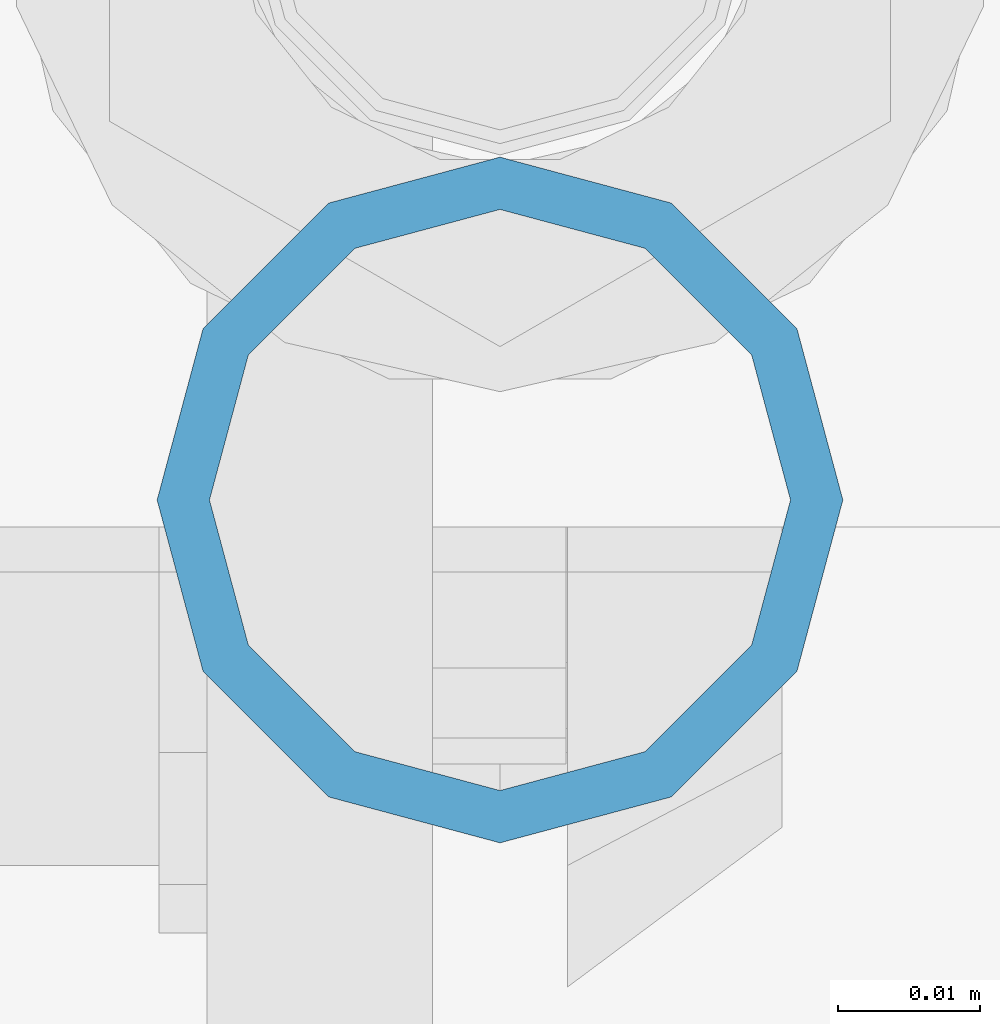
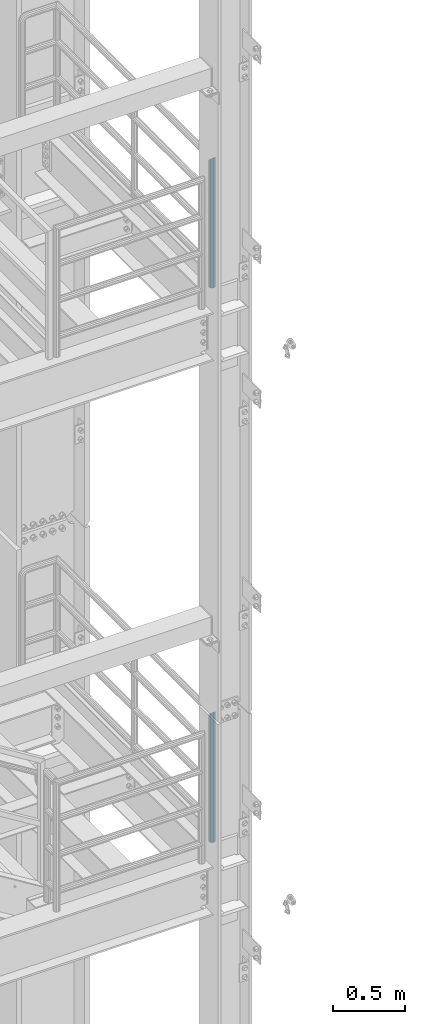
# One storey, part 656 of 1876: 2 columns, 2 elements without a shape of their own.
"""IFC2X3 building model written with IfcOpenShell, lengths in millimetres."""

from ifc_helpers import new_model, si_unit, frame, origin_with_axes, place, context, subcontext, project, spatial, faceted_brep, material, type_object, element, aggregate, save


model = new_model("IFC2X3")

# Units and contexts
model_context = context("Model", 3, precision=1e-05, world=origin_with_axes())
body_context = subcontext(model_context, "Body", "Model", "MODEL_VIEW")
ifc_project = project(units=[si_unit("LENGTHUNIT", "METRE", prefix="MILLI"), si_unit("AREAUNIT", "SQUARE_METRE"), si_unit("VOLUMEUNIT", "CUBIC_METRE"), si_unit("MASSUNIT", "GRAM", prefix="KILO"), si_unit("TIMEUNIT", "SECOND"), si_unit("PLANEANGLEUNIT", "RADIAN"), si_unit("SOLIDANGLEUNIT", "STERADIAN"), si_unit("THERMODYNAMICTEMPERATUREUNIT", "DEGREE_CELSIUS"), si_unit("LUMINOUSINTENSITYUNIT", "LUMEN")], contexts=[model_context])

# Site, building, storey
site_placement = place(None, origin_with_axes())
site = spatial("IfcSite", under=ifc_project, at=site_placement, CompositionType="ELEMENT")
building_placement = place(site_placement, origin_with_axes())
building = spatial("IfcBuilding", under=site, at=building_placement, Name="Undefined", CompositionType="ELEMENT")
storey_placement = place(building_placement, origin_with_axes())
storey = spatial("IfcBuildingStorey", under=building, at=storey_placement, Name="Undefined", CompositionType="ELEMENT", Elevation=0.0)

# Assembly, column
assembly_1_placement = place(storey_placement, origin_with_axes())
assembly_1 = element("IfcElementAssembly", 1, at=assembly_1_placement, inside=storey, Name="RAIL", AssemblyPlace="NOTDEFINED", PredefinedType="RIGID_FRAME")
ifc_material = material()
column_type = type_object("IfcColumnType", Name="PIPE1-1/2SCH40", PredefinedType="NOTDEFINED")
column_1_placement = place(assembly_1_placement, frame((7620.0, -6925.945, 17983.2), z_axis=(0.0, 1.0, 0.0), x_axis=(0.0, 0.0, 1.0)))
column_1 = element("IfcColumn", 2, at=column_1_placement, type_object=column_type, material=ifc_material, Name="POST", ObjectType="PIPE1-1/2SCH40", context=body_context, shape_type="Brep", body=[
    faceted_brep([(0.0, -20.4469999999999, 0.0), (0.0, -17.7076214311803, 10.2235000000001), (1066.1015, -17.7076214311803, 10.2235000000001), (1076.325, -20.4469999999999, 0.0), (0.0, -10.2235000000001, 17.7076214311801), (1058.61737856882, -10.2235000000001, 17.7076214311801), (-1.45519152283669e-11, 0.0, 20.4470000000001), (1055.878, 0.0, 20.4470000000001), (0.0, 10.2235000000001, 17.7076214311801), (1058.61737856882, 10.2235000000001, 17.7076214311801), (0.0, 17.7076214311803, 10.2235000000001), (1066.1015, 17.7076214311803, 10.2235000000001), (0.0, 20.4469999999999, 0.0), (1076.325, 20.4469999999999, 0.0), (0.0, 17.7076214311803, -10.2235000000001), (1086.5485, 17.7076214311803, -10.2235000000001), (0.0, 10.2235000000001, -17.7076214311801), (1094.03262143118, 10.2235000000001, -17.7076214311801), (-1.45519152283669e-11, 0.0, -20.4470000000001), (1096.772, 0.0, -20.4470000000001), (0.0, -10.2235000000001, -17.7076214311801), (1094.03262143118, -10.2235000000001, -17.7076214311801), (0.0, -17.7076214311803, -10.2235000000001), (1086.5485, -17.7076214311803, -10.2235000000001), (0.0, -24.1299999999992, 0.0), (0.0, -20.8971929933184, -12.0649999999996), (1088.39, -20.8971929933184, -12.0649999999996), (1076.325, -24.1300000000001, 0.0), (0.0, -12.0650000000001, -20.8971929933186), (1097.22219299332, -12.0650000000001, -20.8971929933186), (-1.45519152283669e-11, 0.0, -24.130000000001), (1100.455, 0.0, -24.1300000000001), (0.0, 12.0650000000001, -20.8971929933186), (1097.22219299332, 12.0650000000001, -20.8971929933186), (0.0, 20.8971929933184, -12.0649999999996), (1088.39, 20.8971929933184, -12.0649999999996), (0.0, 24.1299999999992, 0.0), (1076.325, 24.1300000000001, 0.0), (0.0, 20.8971929933184, 12.0649999999996), (1064.26, 20.8971929933184, 12.0649999999996), (0.0, 12.0650000000001, 20.8971929933186), (1055.42780700668, 12.0650000000001, 20.8971929933186), (-1.45519152283669e-11, 0.0, 24.130000000001), (1052.195, 0.0, 24.1300000000001), (0.0, -12.0650000000001, 20.8971929933186), (1055.42780700668, -12.0650000000001, 20.8971929933186), (0.0, -20.8971929933184, 12.0649999999996), (1064.26, -20.8971929933184, 12.0649999999996)], [[[0, 1, 2, 3]], [[1, 4, 5, 2]], [[4, 6, 7, 5]], [[6, 8, 9, 7]], [[8, 10, 11, 9]], [[10, 12, 13, 11]], [[12, 14, 15, 13]], [[14, 16, 17, 15]], [[16, 18, 19, 17]], [[18, 20, 21, 19]], [[20, 22, 23, 21]], [[22, 0, 3, 23]], [[24, 25, 26, 27]], [[25, 28, 29, 26]], [[28, 30, 31, 29]], [[30, 32, 33, 31]], [[32, 34, 35, 33]], [[34, 36, 37, 35]], [[36, 38, 39, 37]], [[38, 40, 41, 39]], [[40, 42, 43, 41]], [[42, 44, 45, 43]], [[44, 46, 47, 45]], [[46, 24, 27, 47]], [[29, 31, 33, 35, 37, 39, 41, 43, 45, 47, 27, 26], [5, 7, 9, 11, 13, 15, 17, 19, 21, 23, 3, 2]], [[46, 44, 42, 40, 38, 36, 34, 32, 30, 28, 25, 24], [22, 20, 18, 16, 14, 12, 10, 8, 6, 4, 1, 0]]]),
])
aggregate(assembly_1, [column_1])

assembly_2_placement = place(storey_placement, origin_with_axes())
assembly_2 = element("IfcElementAssembly", 3, at=assembly_2_placement, inside=storey, Name="RAIL", AssemblyPlace="NOTDEFINED", PredefinedType="RIGID_FRAME")
column_2_placement = place(assembly_2_placement, frame((7620.0, -6925.945, 13309.6), z_axis=(0.0, 1.0, 0.0), x_axis=(0.0, 0.0, 1.0)))
column_2 = element("IfcColumn", 4, at=column_2_placement, type_object=column_type, material=ifc_material, Name="POST", ObjectType="PIPE1-1/2SCH40", context=body_context, shape_type="Brep", body=[
    faceted_brep([(0.0, -20.4469999999999, 0.0), (0.0, -17.7076214311803, 10.2235000000001), (1066.1015, -17.7076214311803, 10.2235000000001), (1076.325, -20.4469999999999, 0.0), (0.0, -10.2235000000001, 17.7076214311801), (1058.61737856882, -10.2235000000001, 17.7076214311801), (-1.45519152283669e-11, 0.0, 20.4470000000001), (1055.878, 0.0, 20.4470000000001), (0.0, 10.2235000000001, 17.7076214311801), (1058.61737856882, 10.2235000000001, 17.7076214311801), (0.0, 17.7076214311803, 10.2235000000001), (1066.1015, 17.7076214311803, 10.2235000000001), (0.0, 20.4469999999999, 0.0), (1076.325, 20.4469999999999, 0.0), (0.0, 17.7076214311803, -10.2235000000001), (1086.5485, 17.7076214311803, -10.2235000000001), (0.0, 10.2235000000001, -17.7076214311801), (1094.03262143118, 10.2235000000001, -17.7076214311801), (-1.45519152283669e-11, 0.0, -20.4470000000001), (1096.772, 0.0, -20.4470000000001), (0.0, -10.2235000000001, -17.7076214311801), (1094.03262143118, -10.2235000000001, -17.7076214311801), (0.0, -17.7076214311803, -10.2235000000001), (1086.5485, -17.7076214311803, -10.2235000000001), (0.0, -24.1299999999992, 0.0), (0.0, -20.8971929933184, -12.0649999999996), (1088.39, -20.8971929933184, -12.0649999999996), (1076.325, -24.1300000000001, 0.0), (0.0, -12.0650000000001, -20.8971929933186), (1097.22219299332, -12.0650000000001, -20.8971929933186), (-1.45519152283669e-11, 0.0, -24.130000000001), (1100.455, 0.0, -24.1300000000001), (0.0, 12.0650000000001, -20.8971929933186), (1097.22219299332, 12.0650000000001, -20.8971929933186), (0.0, 20.8971929933184, -12.0649999999996), (1088.39, 20.8971929933184, -12.0649999999996), (0.0, 24.1299999999992, 0.0), (1076.325, 24.1300000000001, 0.0), (0.0, 20.8971929933184, 12.0649999999996), (1064.26, 20.8971929933184, 12.0649999999996), (0.0, 12.0650000000001, 20.8971929933186), (1055.42780700668, 12.0650000000001, 20.8971929933186), (-1.45519152283669e-11, 0.0, 24.130000000001), (1052.195, 0.0, 24.1300000000001), (0.0, -12.0650000000001, 20.8971929933186), (1055.42780700668, -12.0650000000001, 20.8971929933186), (0.0, -20.8971929933184, 12.0649999999996), (1064.26, -20.8971929933184, 12.0649999999996)], [[[0, 1, 2, 3]], [[1, 4, 5, 2]], [[4, 6, 7, 5]], [[6, 8, 9, 7]], [[8, 10, 11, 9]], [[10, 12, 13, 11]], [[12, 14, 15, 13]], [[14, 16, 17, 15]], [[16, 18, 19, 17]], [[18, 20, 21, 19]], [[20, 22, 23, 21]], [[22, 0, 3, 23]], [[24, 25, 26, 27]], [[25, 28, 29, 26]], [[28, 30, 31, 29]], [[30, 32, 33, 31]], [[32, 34, 35, 33]], [[34, 36, 37, 35]], [[36, 38, 39, 37]], [[38, 40, 41, 39]], [[40, 42, 43, 41]], [[42, 44, 45, 43]], [[44, 46, 47, 45]], [[46, 24, 27, 47]], [[29, 31, 33, 35, 37, 39, 41, 43, 45, 47, 27, 26], [5, 7, 9, 11, 13, 15, 17, 19, 21, 23, 3, 2]], [[46, 44, 42, 40, 38, 36, 34, 32, 30, 28, 25, 24], [22, 20, 18, 16, 14, 12, 10, 8, 6, 4, 1, 0]]]),
])
aggregate(assembly_2, [column_2])

save(model, "model.ifc")
